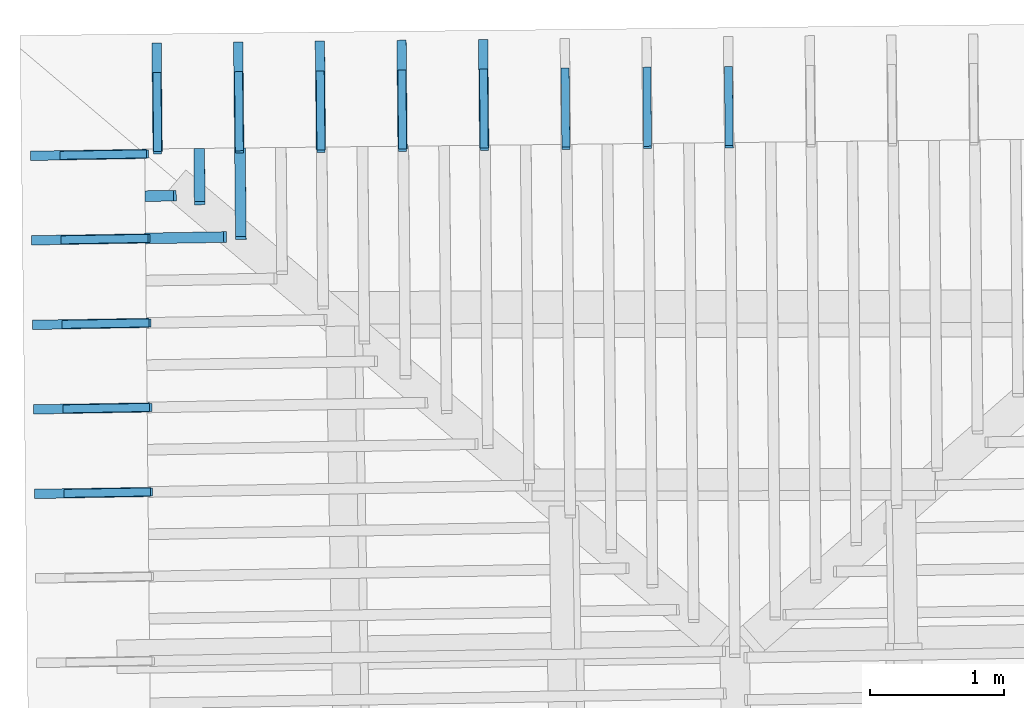
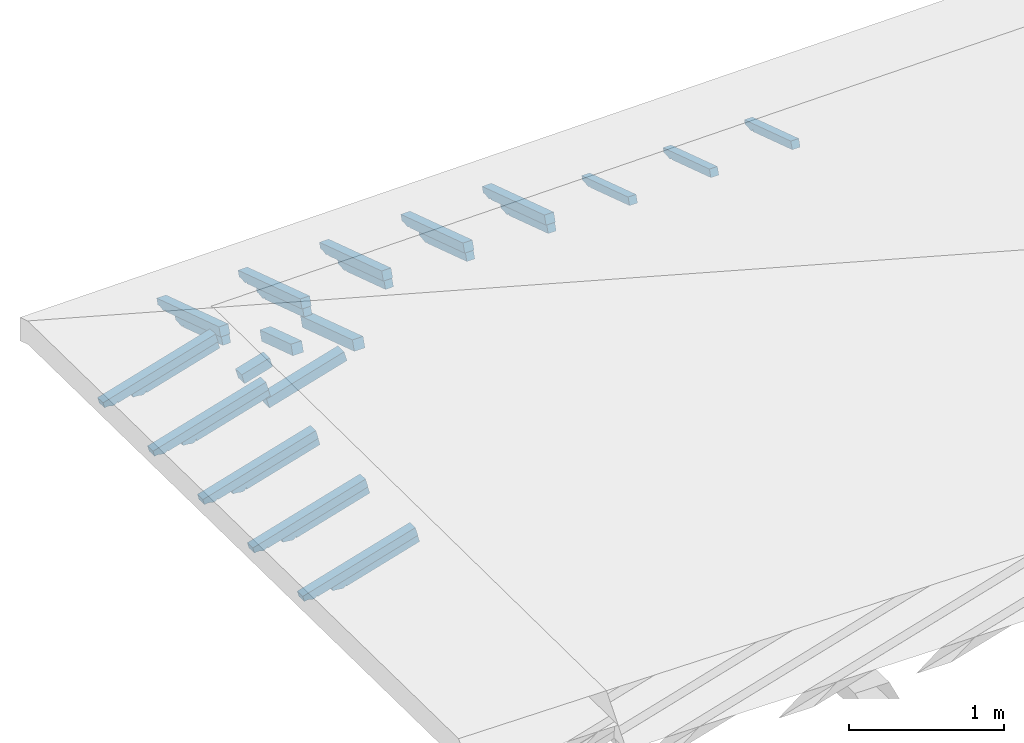
# One storey, part 15 of 19: 27 beams, 6 elements without a shape of their own.
"""IFC4 building model written with IfcOpenShell, lengths in metres."""

from ifc_helpers import new_model, entity, si_unit, converted_unit, derived_unit, direction, frame, origin, place, context, subcontext, project, spatial, line, arc, indexed_curve, outline, extrude, source, transform, mapped, material, type_object, type_shapes, element, aggregate, save


model = new_model("IFC4")

# Units and contexts
model_context = context("Model", 3, precision=1e-05, world=origin(), true_north=direction((6.123233995736766e-17, 1.0)))
body_context = subcontext(model_context, "Body", "Model", "MODEL_VIEW")
ifc_project = project(units=[si_unit("LENGTHUNIT", "METRE"), si_unit("AREAUNIT", "SQUARE_METRE"), si_unit("VOLUMEUNIT", "CUBIC_METRE"), converted_unit("PLANEANGLEUNIT", "DEGREE", entity("IfcPlaneAngleMeasure", 0.017453292519943278), si_unit("PLANEANGLEUNIT", "RADIAN"), dimensions=[0, 0, 0, 0, 0, 0, 0]), derived_unit("THERMALTRANSMITTANCEUNIT", [(si_unit("MASSUNIT", "GRAM", prefix="KILO"), 1), (si_unit("THERMODYNAMICTEMPERATUREUNIT", "KELVIN"), -1), (si_unit("TIMEUNIT", "SECOND"), -3)])], contexts=[model_context])

# Site, building, storey
site_placement = place(None, origin())
site = spatial("IfcSite", under=ifc_project, at=site_placement, CompositionType="ELEMENT")
building_placement = place(site_placement, origin())
building = spatial("IfcBuilding", under=site, at=building_placement, CompositionType="ELEMENT")
storey_placement = place(building_placement, frame((0.0, 0.0, 3.28)))
storey = spatial("IfcBuildingStorey", under=building, at=storey_placement, Name="Livello Copertura", CompositionType="ELEMENT", Elevation=3.28)

# Assembly, beams
assembly_1_placement = place(storey_placement, origin())
assembly_1 = element("IfcElementAssembly", 1, at=assembly_1_placement, inside=storey, Name="Sistema di travi strutturali:Sistema di travi strutturali", ObjectType="Sistema di travi strutturali:Sistema di travi strutturali", AssemblyPlace="NOTDEFINED", PredefinedType="BEAM_GRID")
ifc_material = material(Name="Legno - Legno da costruzione", Category="Legno")
beam_type_1 = type_object("IfcBeamType", Name="Legno:80x80", PredefinedType="JOIST", material=ifc_material)
shared_shape_1 = source(origin(), body_context, "Body", "SweptSolid", [
    extrude(outline(indexed_curve([(-0.10950000000000001, -0.04000000000000169), (0.10950000000000001, -0.04000000000000169), (0.10950000000000001, 0.04000000000000169), (-0.10950000000000001, 0.04000000000000169), (-0.10950000000000001, -0.04000000000000169)], self_intersect=False)), frame((0.0, 0.0, -0.040000000000005476), z_axis=(0.0, 0.0, 1.0), x_axis=(-1.0, 0.0, 0.0)), (0.0, 0.0, 1.0), 0.07999999999999997),
])
type_shapes(beam_type_1, [shared_shape_1])
beam_1_placement = place(assembly_1_placement, frame((-4.582253934922218, 15.732475619710598, 0.14532260116264584), z_axis=(-0.26888056974925345, -0.004594467440668278, 0.9631625667976582), x_axis=(0.9630219859926786, 0.01645553326302543, 0.26891982061526537)))
beam_1 = element("IfcBeam", 2, at=beam_1_placement, type_object=beam_type_1, material=ifc_material, Name="Legno:80x80", ObjectType="Legno:80x80", PredefinedType="JOIST", context=body_context, shape_type="MappedRepresentation", body=[
    mapped(shared_shape_1, transform((0.0, 0.0, 0.0), scale=1.0)),
])
beam_type_2 = type_object("IfcBeamType", Name="Legno:80x80", PredefinedType="JOIST", material=ifc_material)
shared_shape_2 = source(origin(), body_context, "Body", "SweptSolid", [
    extrude(outline(indexed_curve([(-0.3025, -0.04000000000000169), (0.3025, -0.04000000000000169), (0.3025, 0.04000000000000169), (-0.3025, 0.04000000000000169), (-0.3025, -0.04000000000000169)], self_intersect=False)), frame((0.0, 0.0, -0.040000000000005476), z_axis=(0.0, 0.0, 1.0), x_axis=(-1.0, 0.0, 0.0)), (0.0, 0.0, 1.0), 0.07999999999999997),
])
type_shapes(beam_type_2, [shared_shape_2])
beam_2_placement = place(assembly_1_placement, frame((-4.3932646673043765, 15.420658969904737, 0.19659422675413696), z_axis=(-0.2688805697492527, -0.004594467440668261, 0.9631625667976585), x_axis=(0.963021985992679, 0.016455533263023885, 0.26891982061526454)))
beam_2 = element("IfcBeam", 3, at=beam_2_placement, type_object=beam_type_2, material=ifc_material, Name="Legno:80x80", ObjectType="Legno:80x80", PredefinedType="JOIST", context=body_context, shape_type="MappedRepresentation", body=[
    mapped(shared_shape_2, transform((0.0, 0.0, 0.0), scale=1.0)),
])
aggregate(assembly_1, [beam_1, beam_2])

assembly_2_placement = place(storey_placement, origin())
assembly_2 = element("IfcElementAssembly", 4, at=assembly_2_placement, inside=storey, Name="Sistema di travi strutturali:Sistema di travi strutturali", ObjectType="Sistema di travi strutturali:Sistema di travi strutturali", AssemblyPlace="NOTDEFINED", PredefinedType="BEAM_GRID")
beam_type_3 = type_object("IfcBeamType", Name="Legno:80x80", PredefinedType="JOIST", material=ifc_material)
shared_shape_3 = source(origin(), body_context, "Body", "SweptSolid", [
    extrude(outline(indexed_curve([(-0.2075, -0.04000000000000169), (0.2075, -0.04000000000000169), (0.2075, 0.04000000000000169), (-0.2075, 0.04000000000000169), (-0.2075, -0.04000000000000169)], self_intersect=False)), frame((0.0, 0.0, -0.040000000000005476), z_axis=(0.0, 0.0, 1.0), x_axis=(-1.0, 0.0, 0.0)), (0.0, 0.0, 1.0), 0.07999999999999997),
])
type_shapes(beam_type_3, [shared_shape_3])
beam_3_placement = place(assembly_2_placement, frame((-4.293384356106456, 15.876184895349297, 0.16696005804398784), z_axis=(-0.007186655942142942, 0.30161875858893405, 0.9534015294951229), x_axis=(0.009276659863625233, -0.9533650144726797, 0.30167713330857865)))
beam_3 = element("IfcBeam", 5, at=beam_3_placement, type_object=beam_type_3, material=ifc_material, Name="Legno:80x80", ObjectType="Legno:80x80", PredefinedType="JOIST", context=body_context, shape_type="MappedRepresentation", body=[
    mapped(shared_shape_3, transform((0.0, 0.0, 0.0), scale=1.0)),
])
beam_type_4 = type_object("IfcBeamType", Name="Legno:80x80", PredefinedType="JOIST", material=ifc_material)
shared_shape_4 = source(origin(), body_context, "Body", "SweptSolid", [
    extrude(outline(indexed_curve([(-0.34550000000000003, -0.04000000000000169), (0.34550000000000003, -0.04000000000000169), (0.34550000000000003, 0.04000000000000169), (-0.34550000000000003, 0.04000000000000169), (-0.34550000000000003, -0.04000000000000169)], self_intersect=False)), frame((0.0, 0.0, -0.040000000000005476), z_axis=(0.0, 0.0, 1.0), x_axis=(-1.0, 0.0, 0.0)), (0.0, 0.0, 1.0), 0.07999999999999997),
])
type_shapes(beam_type_4, [shared_shape_4])
beam_4_placement = place(assembly_2_placement, frame((-3.9878263051044196, 15.748092423715986, 0.20978674921066975), z_axis=(-0.007186655942142939, 0.3016187585889339, 0.9534015294951229), x_axis=(0.009276659863626028, -0.9533650144726799, 0.3016771333085785)))
beam_4 = element("IfcBeam", 6, at=beam_4_placement, type_object=beam_type_4, material=ifc_material, Name="Legno:80x80", ObjectType="Legno:80x80", PredefinedType="JOIST", context=body_context, shape_type="MappedRepresentation", body=[
    mapped(shared_shape_4, transform((0.0, 0.0, 0.0), scale=1.0)),
])
aggregate(assembly_2, [beam_3, beam_4])

assembly_3_placement = place(storey_placement, origin())
assembly_3 = element("IfcElementAssembly", 7, at=assembly_3_placement, inside=storey, Name="Sistema di travi strutturali:Sistema di travi strutturali", ObjectType="Sistema di travi strutturali:Sistema di travi strutturali", AssemblyPlace="NOTDEFINED", PredefinedType="BEAM_GRID")
beam_type_5 = type_object("IfcBeamType", Name="70x70:70x70", PredefinedType="JOIST", material=ifc_material)
shared_shape_5 = source(origin(), body_context, "Body", "SweptSolid", [
    extrude(outline(indexed_curve([(-0.04357142857143151, -0.5561428571428565), (0.026428571428568467, -0.5561428571428565), (0.026428571428568467, 0.1728571428571433), (0.012428571428584355, 0.1728571428571399), (0.026181867029378872, 0.19656674738504454), (0.018428571428570788, 0.22285714285714342), (0.006014118110847752, 0.24585271837212633), (0.0034285714285709526, 0.27185714285714324), (-0.04357142857143151, 0.27185714285714324)], segments=[line(1, 2, 3, 4), arc(4, 5, 6), arc(6, 7, 8), line(8, 9, 1)], self_intersect=False)), frame((-0.10714285714285654, -0.03500000000000078, -0.008571428571433252), z_axis=(0.0, 1.0, 0.0), x_axis=(0.0, 0.0, -1.0)), (0.0, 0.0, 1.0), 0.06999999999999999),
])
type_shapes(beam_type_5, [shared_shape_5])
beam_5_placement = place(assembly_3_placement, frame((-4.609130134095698, 16.50076191580006, 0.10539004595002055), z_axis=(-0.007186655942142929, 0.30161875858893394, 0.9534015294951229), x_axis=(0.009276659863625622, -0.9533650144726796, 0.3016771333085786)))
beam_5 = element("IfcBeam", 8, at=beam_5_placement, type_object=beam_type_5, material=ifc_material, Name="70x70:70x70", ObjectType="70x70:70x70", PredefinedType="JOIST", context=body_context, shape_type="MappedRepresentation", body=[
    mapped(shared_shape_5, transform((0.0, 0.0, 0.0), scale=1.0)),
])
beam_6_placement = place(assembly_3_placement, frame((-4.000572039000026, 16.507464081589834, 0.10785700100738804), z_axis=(-0.007186655942142923, 0.3016187585889335, 0.953401529495123), x_axis=(0.009276659863625115, -0.95336501447268, 0.3016771333085781)))
beam_6 = element("IfcBeam", 9, at=beam_6_placement, type_object=beam_type_5, material=ifc_material, Name="70x70:70x70", ObjectType="70x70:70x70", PredefinedType="JOIST", context=body_context, shape_type="MappedRepresentation", body=[
    mapped(shared_shape_5, transform((0.0, 0.0, 0.0), scale=1.0)),
])
beam_7_placement = place(assembly_3_placement, frame((-3.392013943904355, 16.51416624737961, 0.11032395606475465), z_axis=(-0.0071866559421429246, 0.3016187585889335, 0.953401529495123), x_axis=(0.009276659863625207, -0.95336501447268, 0.3016771333085781)))
beam_7 = element("IfcBeam", 10, at=beam_7_placement, type_object=beam_type_5, material=ifc_material, Name="70x70:70x70", ObjectType="70x70:70x70", PredefinedType="JOIST", context=body_context, shape_type="MappedRepresentation", body=[
    mapped(shared_shape_5, transform((0.0, 0.0, 0.0), scale=1.0)),
])
beam_8_placement = place(assembly_3_placement, frame((-2.783455848808685, 16.52086841316939, 0.11279091112212125), z_axis=(-0.007186655942142926, 0.3016187585889337, 0.953401529495123), x_axis=(0.009276659863625325, -0.9533650144726799, 0.3016771333085783)))
beam_8 = element("IfcBeam", 11, at=beam_8_placement, type_object=beam_type_5, material=ifc_material, Name="70x70:70x70", ObjectType="70x70:70x70", PredefinedType="JOIST", context=body_context, shape_type="MappedRepresentation", body=[
    mapped(shared_shape_5, transform((0.0, 0.0, 0.0), scale=1.0)),
])
beam_9_placement = place(assembly_3_placement, frame((-2.1748977537130134, 16.527570578959164, 0.11525786617948608), z_axis=(-0.007186655942142926, 0.3016187585889336, 0.953401529495123), x_axis=(0.00927665986362572, -0.9533650144726797, 0.30167713330857826)))
beam_9 = element("IfcBeam", 12, at=beam_9_placement, type_object=beam_type_5, material=ifc_material, Name="70x70:70x70", ObjectType="70x70:70x70", PredefinedType="JOIST", context=body_context, shape_type="MappedRepresentation", body=[
    mapped(shared_shape_5, transform((0.0, 0.0, 0.0), scale=1.0)),
])
aggregate(assembly_3, [beam_5, beam_6, beam_7, beam_8, beam_9])

assembly_4_placement = place(storey_placement, origin())
assembly_4 = element("IfcElementAssembly", 13, at=assembly_4_placement, inside=storey, Name="Sistema di travi strutturali:Sistema di travi strutturali", ObjectType="Sistema di travi strutturali:Sistema di travi strutturali", AssemblyPlace="NOTDEFINED", PredefinedType="BEAM_GRID")
beam_type_6 = type_object("IfcBeamType", Name="60x60:60x60", PredefinedType="JOIST", material=ifc_material)
shared_shape_6 = source(origin(), body_context, "Body", "SweptSolid", [
    extrude(outline(indexed_curve([(-0.035857142857117906, -0.404857142857143), (0.02414285714288207, -0.404857142857143), (0.02414285714288207, 0.11414285714285698), (0.007142857142882135, 0.11414285714285698), (0.02280031419839907, 0.1317392731984247), (0.02014285714279438, 0.1551428571428581), (0.006097362558745583, 0.1832964455908379), (-0.003857142857204834, 0.21314285714285694), (-0.035857142857117906, 0.21314285714285702)], segments=[line(1, 2, 3, 4), arc(4, 5, 6), arc(6, 7, 8), line(8, 9, 1)], self_intersect=False)), frame((0.04414285714285706, -0.030000000000000786, -0.005857142857119645), z_axis=(0.0, 1.0, 0.0), x_axis=(0.0, 0.0, -1.0)), (0.0, 0.0, 1.0), 0.059999999999999984),
])
type_shapes(beam_type_6, [shared_shape_6])
beam_10_placement = place(assembly_4_placement, frame((-4.608663001459457, 16.481156696491773, 0.0434189465328334), z_axis=(-0.007186655942142926, 0.30161875858893394, 0.9534015294951229), x_axis=(0.009276659863625622, -0.9533650144726796, 0.3016771333085786)))
beam_10 = element("IfcBeam", 14, at=beam_10_placement, type_object=beam_type_6, material=ifc_material, Name="60x60:60x60", ObjectType="60x60:60x60", PredefinedType="JOIST", context=body_context, shape_type="MappedRepresentation", body=[
    mapped(shared_shape_6, transform((0.0, 0.0, 0.0), scale=1.0)),
])
beam_11_placement = place(assembly_4_placement, frame((-4.000104906363788, 16.48785886228155, 0.04588590159020178), z_axis=(-0.0071866559421429246, 0.3016187585889335, 0.9534015294951231), x_axis=(0.009276659863625115, -0.95336501447268, 0.3016771333085781)))
beam_11 = element("IfcBeam", 15, at=beam_11_placement, type_object=beam_type_6, material=ifc_material, Name="60x60:60x60", ObjectType="60x60:60x60", PredefinedType="JOIST", context=body_context, shape_type="MappedRepresentation", body=[
    mapped(shared_shape_6, transform((0.0, 0.0, 0.0), scale=1.0)),
])
beam_12_placement = place(assembly_4_placement, frame((-3.3915468112681166, 16.49456102807133, 0.0483528566475675), z_axis=(-0.007186655942142923, 0.3016187585889335, 0.9534015294951231), x_axis=(0.009276659863625207, -0.95336501447268, 0.3016771333085781)))
beam_12 = element("IfcBeam", 16, at=beam_12_placement, type_object=beam_type_6, material=ifc_material, Name="60x60:60x60", ObjectType="60x60:60x60", PredefinedType="JOIST", context=body_context, shape_type="MappedRepresentation", body=[
    mapped(shared_shape_6, transform((0.0, 0.0, 0.0), scale=1.0)),
])
beam_13_placement = place(assembly_4_placement, frame((-2.7829887161724463, 16.501263193861107, 0.050819811704934104), z_axis=(-0.0071866559421429246, 0.3016187585889337, 0.953401529495123), x_axis=(0.009276659863625325, -0.9533650144726799, 0.3016771333085783)))
beam_13 = element("IfcBeam", 17, at=beam_13_placement, type_object=beam_type_6, material=ifc_material, Name="60x60:60x60", ObjectType="60x60:60x60", PredefinedType="JOIST", context=body_context, shape_type="MappedRepresentation", body=[
    mapped(shared_shape_6, transform((0.0, 0.0, 0.0), scale=1.0)),
])
beam_14_placement = place(assembly_4_placement, frame((-2.174430621076774, 16.507965359650882, 0.053286766762301596), z_axis=(-0.0071866559421429246, 0.3016187585889336, 0.953401529495123), x_axis=(0.00927665986362572, -0.9533650144726797, 0.30167713330857826)))
beam_14 = element("IfcBeam", 18, at=beam_14_placement, type_object=beam_type_6, material=ifc_material, Name="60x60:60x60", ObjectType="60x60:60x60", PredefinedType="JOIST", context=body_context, shape_type="MappedRepresentation", body=[
    mapped(shared_shape_6, transform((0.0, 0.0, 0.0), scale=1.0)),
])
beam_15_placement = place(assembly_4_placement, frame((-1.565872525981103, 16.51466752544066, 0.05575372181966731), z_axis=(-0.007186655942142925, 0.30161875858893367, 0.953401529495123), x_axis=(0.009276659863625813, -0.9533650144726797, 0.3016771333085783)))
beam_15 = element("IfcBeam", 19, at=beam_15_placement, type_object=beam_type_6, material=ifc_material, Name="60x60:60x60", ObjectType="60x60:60x60", PredefinedType="JOIST", context=body_context, shape_type="MappedRepresentation", body=[
    mapped(shared_shape_6, transform((0.0, 0.0, 0.0), scale=1.0)),
])
beam_16_placement = place(assembly_4_placement, frame((-0.9573144308854326, 16.521369691230436, 0.05822067687703214), z_axis=(-0.007186655942142933, 0.30161875858893444, 0.9534015294951228), x_axis=(0.009276659863625778, -0.9533650144726795, 0.3016771333085791)))
beam_16 = element("IfcBeam", 20, at=beam_16_placement, type_object=beam_type_6, material=ifc_material, Name="60x60:60x60", ObjectType="60x60:60x60", PredefinedType="JOIST", context=body_context, shape_type="MappedRepresentation", body=[
    mapped(shared_shape_6, transform((0.0, 0.0, 0.0), scale=1.0)),
])
beam_17_placement = place(assembly_4_placement, frame((-0.3487563357897622, 16.52807185702022, 0.06068763193439608), z_axis=(-0.007186655942142919, 0.3016187585889333, 0.9534015294951231), x_axis=(0.009276659863625625, -0.95336501447268, 0.30167713330857787)))
beam_17 = element("IfcBeam", 21, at=beam_17_placement, type_object=beam_type_6, material=ifc_material, Name="60x60:60x60", ObjectType="60x60:60x60", PredefinedType="JOIST", context=body_context, shape_type="MappedRepresentation", body=[
    mapped(shared_shape_6, transform((0.0, 0.0, 0.0), scale=1.0)),
])
aggregate(assembly_4, [beam_10, beam_11, beam_12, beam_13, beam_14, beam_15, beam_16, beam_17])

assembly_5_placement = place(storey_placement, origin())
assembly_5 = element("IfcElementAssembly", 22, at=assembly_5_placement, inside=storey, Name="Sistema di travi strutturali:Sistema di travi strutturali", ObjectType="Sistema di travi strutturali:Sistema di travi strutturali", AssemblyPlace="NOTDEFINED", PredefinedType="BEAM_GRID")
beam_type_7 = type_object("IfcBeamType", Name="70x70:70x70", PredefinedType="JOIST", material=ifc_material)
shared_shape_7 = source(origin(), body_context, "Body", "SweptSolid", [
    extrude(outline(indexed_curve([(-0.043571428571431495, -0.5925714285714281), (0.026428571428568505, -0.5925714285714281), (0.026428571428568505, 0.18742857142857194), (0.012428571428584407, 0.18742857142856856), (0.026181867029378924, 0.2111381759564732), (0.018428571428570704, 0.23742857142857207), (0.006014118110847667, 0.260424146943555), (0.0034285714285708724, 0.2864285714285719), (-0.043571428571431495, 0.2864285714285719)], segments=[line(1, 2, 3, 4), arc(4, 5, 6), arc(6, 7, 8), line(8, 9, 1)], self_intersect=False)), frame((-0.11807142857142808, -0.03500000000000078, -0.00857142857143322), z_axis=(0.0, 1.0, 0.0), x_axis=(0.0, 0.0, -1.0)), (0.0, 0.0, 1.0), 0.06999999999999999),
])
type_shapes(beam_type_7, [shared_shape_7])
beam_18_placement = place(assembly_5_placement, frame((-5.1243446077535815, 13.517890821120742, 0.12049828356343428), z_axis=(-0.2688805697492533, -0.004594467440668784, 0.9631625667976583), x_axis=(0.9630219859926786, 0.016455533263033163, 0.26891982061526526)))
beam_18 = element("IfcBeam", 23, at=beam_18_placement, type_object=beam_type_7, material=ifc_material, Name="70x70:70x70", ObjectType="70x70:70x70", PredefinedType="JOIST", context=body_context, shape_type="MappedRepresentation", body=[
    mapped(shared_shape_7, transform((0.0, 0.0, 0.0), scale=1.0)),
])
beam_type_8 = type_object("IfcBeamType", Name="70x70:70x70", PredefinedType="JOIST", material=ifc_material)
shared_shape_8 = source(origin(), body_context, "Body", "SweptSolid", [
    extrude(outline(indexed_curve([(-0.04357142857143151, -0.5932857142857139), (0.026428571428568484, -0.5932857142857139), (0.026428571428568484, 0.18771428571428622), (0.012428571428584384, 0.18771428571428284), (0.026181867029378903, 0.21142389024218747), (0.01842857142857075, 0.23771428571428635), (0.006014118110847714, 0.26070986122926926), (0.0034285714285709197, 0.2867142857142862), (-0.04357142857143151, 0.2867142857142862)], segments=[line(1, 2, 3, 4), arc(4, 5, 6), arc(6, 7, 8), line(8, 9, 1)], self_intersect=False)), frame((-0.11828571428571381, -0.03500000000000078, -0.008571428571433238), z_axis=(0.0, 1.0, 0.0), x_axis=(0.0, 0.0, -1.0)), (0.0, 0.0, 1.0), 0.06999999999999999),
])
type_shapes(beam_type_8, [shared_shape_8])
beam_19_placement = place(assembly_5_placement, frame((-5.131125982898225, 14.147866911763051, 0.12161027094874166), z_axis=(-0.26888056974925323, -0.004594467440668785, 0.9631625667976583), x_axis=(0.9630219859926786, 0.016455533263032632, 0.2689198206152652)))
beam_19 = element("IfcBeam", 24, at=beam_19_placement, type_object=beam_type_8, material=ifc_material, Name="70x70:70x70", ObjectType="70x70:70x70", PredefinedType="JOIST", context=body_context, shape_type="MappedRepresentation", body=[
    mapped(shared_shape_8, transform((0.0, 0.0, 0.0), scale=1.0)),
])
beam_type_9 = type_object("IfcBeamType", Name="70x70:70x70", PredefinedType="JOIST", material=ifc_material)
shared_shape_9 = source(origin(), body_context, "Body", "SweptSolid", [
    extrude(outline(indexed_curve([(-0.043571428571431536, -0.5939999999999996), (0.026428571428568453, -0.5939999999999996), (0.026428571428568453, 0.1880000000000005), (0.012428571428584355, 0.1879999999999971), (0.026181867029378872, 0.21170960452790177), (0.018428571428570822, 0.23800000000000066), (0.006014118110847787, 0.26099557551498354), (0.003428571428570993, 0.2870000000000005), (-0.043571428571431536, 0.2870000000000005)], segments=[line(1, 2, 3, 4), arc(4, 5, 6), arc(6, 7, 8), line(8, 9, 1)], self_intersect=False)), frame((-0.11849999999999952, -0.03500000000000078, -0.008571428571433268), z_axis=(0.0, 1.0, 0.0), x_axis=(0.0, 0.0, -1.0)), (0.0, 0.0, 1.0), 0.06999999999999999),
])
type_shapes(beam_type_9, [shared_shape_9])
beam_20_placement = place(assembly_5_placement, frame((-5.1379073580428685, 14.777843002405358, 0.12272225833405237), z_axis=(-0.26888056974925306, -0.004594467440668779, 0.9631625667976584), x_axis=(0.9630219859926787, 0.016455533263032122, 0.268919820615265)))
beam_20 = element("IfcBeam", 25, at=beam_20_placement, type_object=beam_type_9, material=ifc_material, Name="70x70:70x70", ObjectType="70x70:70x70", PredefinedType="JOIST", context=body_context, shape_type="MappedRepresentation", body=[
    mapped(shared_shape_9, transform((0.0, 0.0, 0.0), scale=1.0)),
])
beam_type_10 = type_object("IfcBeamType", Name="70x70:70x70", PredefinedType="JOIST", material=ifc_material)
shared_shape_10 = source(origin(), body_context, "Body", "SweptSolid", [
    extrude(outline(indexed_curve([(-0.04357142857143148, -0.5947142857142853), (0.026428571428568495, -0.5947142857142853), (0.026428571428568495, 0.18828571428571472), (0.012428571428584384, 0.18828571428571134), (0.026181867029378903, 0.211995318813616), (0.01842857142857071, 0.23828571428571502), (0.006014118110847678, 0.2612812898006979), (0.003428571428570883, 0.2872857142857148), (-0.04357142857143148, 0.2872857142857148)], segments=[line(1, 2, 3, 4), arc(4, 5, 6), arc(6, 7, 8), line(8, 9, 1)], self_intersect=False)), frame((-0.1187142857142852, -0.03500000000000078, -0.008571428571433224), z_axis=(0.0, 1.0, 0.0), x_axis=(0.0, 0.0, -1.0)), (0.0, 0.0, 1.0), 0.06999999999999999),
])
type_shapes(beam_type_10, [shared_shape_10])
beam_21_placement = place(assembly_5_placement, frame((-5.144688733187512, 15.407819093047673, 0.12383424571936041), z_axis=(-0.26888056974925356, -0.004594467440668789, 0.9631625667976583), x_axis=(0.9630219859926786, 0.01645553326303163, 0.2689198206152655)))
beam_21 = element("IfcBeam", 26, at=beam_21_placement, type_object=beam_type_10, material=ifc_material, Name="70x70:70x70", ObjectType="70x70:70x70", PredefinedType="JOIST", context=body_context, shape_type="MappedRepresentation", body=[
    mapped(shared_shape_10, transform((0.0, 0.0, 0.0), scale=1.0)),
])
beam_type_11 = type_object("IfcBeamType", Name="70x70:70x70", PredefinedType="JOIST", material=ifc_material)
shared_shape_11 = source(origin(), body_context, "Body", "SweptSolid", [
    extrude(outline(indexed_curve([(-0.04357142857143152, -0.5918571428571423), (0.026428571428568467, -0.5918571428571423), (0.026428571428568467, 0.1871428571428576), (0.012428571428584367, 0.18714285714285422), (0.026181867029378882, 0.21085246167075886), (0.018428571428570798, 0.23714285714285774), (0.006014118110847763, 0.26013843265784065), (0.0034285714285709687, 0.2861428571428576), (-0.04357142857143152, 0.2861428571428576)], segments=[line(1, 2, 3, 4), arc(4, 5, 6), arc(6, 7, 8), line(8, 9, 1)], self_intersect=False)), frame((-0.11785714285714236, -0.03500000000000078, -0.008571428571433257), z_axis=(0.0, 1.0, 0.0), x_axis=(0.0, 0.0, -1.0)), (0.0, 0.0, 1.0), 0.06999999999999999),
])
type_shapes(beam_type_11, [shared_shape_11])
beam_22_placement = place(assembly_5_placement, frame((-5.154192466640167, 16.037748665689, 0.12418602604970252), z_axis=(-0.2688805697492532, -0.004594467440668783, 0.9631625667976583), x_axis=(0.9630219859926786, 0.016455533263032052, 0.2689198206152651)))
beam_22 = element("IfcBeam", 27, at=beam_22_placement, type_object=beam_type_11, material=ifc_material, Name="70x70:70x70", ObjectType="70x70:70x70", PredefinedType="JOIST", context=body_context, shape_type="MappedRepresentation", body=[
    mapped(shared_shape_11, transform((0.0, 0.0, 0.0), scale=1.0)),
])
aggregate(assembly_5, [beam_18, beam_19, beam_20, beam_21, beam_22])

assembly_6_placement = place(storey_placement, origin())
assembly_6 = element("IfcElementAssembly", 28, at=assembly_6_placement, inside=storey, Name="Sistema di travi strutturali:Sistema di travi strutturali", ObjectType="Sistema di travi strutturali:Sistema di travi strutturali", AssemblyPlace="NOTDEFINED", PredefinedType="BEAM_GRID")
beam_type_12 = type_object("IfcBeamType", Name="60x60:60x60", PredefinedType="JOIST", material=ifc_material)
shared_shape_12 = source(origin(), body_context, "Body", "SweptSolid", [
    extrude(outline(indexed_curve([(-0.035857142857117275, -0.4412857142857144), (0.024142857142882706, -0.4412857142857144), (0.024142857142882706, 0.12871428571428561), (0.007142857142882865, 0.12871428571428567), (0.022800314198399802, 0.1463107017698534), (0.020142857142792746, 0.16971428571428657), (0.00609736255874395, 0.19786787416226634), (-0.003857142857206467, 0.2277142857142854), (-0.035857142857117275, 0.22771428571428565)], segments=[line(1, 2, 3, 4), arc(4, 5, 6), arc(6, 7, 8), line(8, 9, 1)], self_intersect=False)), frame((0.03321428571428553, -0.030000000000000786, -0.00585714285711901), z_axis=(0.0, 1.0, 0.0), x_axis=(0.0, 0.0, -1.0)), (0.0, 0.0, 1.0), 0.059999999999999984),
])
type_shapes(beam_type_12, [shared_shape_12])
beam_23_placement = place(assembly_6_placement, frame((-5.106867370719879, 13.518189461504386, 0.05789271672158569), z_axis=(-0.2688805697492533, -0.004594467440668784, 0.9631625667976583), x_axis=(0.9630219859926786, 0.016455533263033163, 0.26891982061526526)))
beam_23 = element("IfcBeam", 29, at=beam_23_placement, type_object=beam_type_12, material=ifc_material, Name="60x60:60x60", ObjectType="60x60:60x60", PredefinedType="JOIST", context=body_context, shape_type="MappedRepresentation", body=[
    mapped(shared_shape_12, transform((0.0, 0.0, 0.0), scale=1.0)),
])
beam_type_13 = type_object("IfcBeamType", Name="60x60:60x60", PredefinedType="JOIST", material=ifc_material)
shared_shape_13 = source(origin(), body_context, "Body", "SweptSolid", [
    extrude(outline(indexed_curve([(-0.0358571428571177, -0.4420000000000002), (0.024142857142882283, -0.4420000000000002), (0.024142857142882283, 0.12899999999999986), (0.007142857142882347, 0.12899999999999986), (0.02280031419839928, 0.14659641605556759), (0.020142857142793846, 0.170000000000001), (0.0060973625587450505, 0.19815358844798078), (-0.003857142857205366, 0.22799999999999981), (-0.0358571428571177, 0.22799999999999987)], segments=[line(1, 2, 3, 4), arc(4, 5, 6), arc(6, 7, 8), line(8, 9, 1)], self_intersect=False)), frame((0.03299999999999989, -0.030000000000000786, -0.005857142857119433), z_axis=(0.0, 1.0, 0.0), x_axis=(0.0, 0.0, -1.0)), (0.0, 0.0, 1.0), 0.059999999999999984),
])
type_shapes(beam_type_13, [shared_shape_13])
beam_24_placement = place(assembly_6_placement, frame((-5.1136487458645234, 14.148165552146695, 0.05900470410689396), z_axis=(-0.26888056974925323, -0.004594467440668785, 0.9631625667976583), x_axis=(0.9630219859926786, 0.016455533263032632, 0.2689198206152652)))
beam_24 = element("IfcBeam", 30, at=beam_24_placement, type_object=beam_type_13, material=ifc_material, Name="60x60:60x60", ObjectType="60x60:60x60", PredefinedType="JOIST", context=body_context, shape_type="MappedRepresentation", body=[
    mapped(shared_shape_13, transform((0.0, 0.0, 0.0), scale=1.0)),
])
beam_type_14 = type_object("IfcBeamType", Name="60x60:60x60", PredefinedType="JOIST", material=ifc_material)
shared_shape_14 = source(origin(), body_context, "Body", "SweptSolid", [
    extrude(outline(indexed_curve([(-0.035857142857117705, -0.442714285714286), (0.024142857142882276, -0.442714285714286), (0.024142857142882276, 0.12928571428571417), (0.007142857142882338, 0.12928571428571417), (0.02280031419839927, 0.1468821303412819), (0.020142857142793874, 0.17028571428571532), (0.006097362558745075, 0.1984393027336951), (-0.003857142857205342, 0.22828571428571412), (-0.035857142857117705, 0.2282857142857142)], segments=[line(1, 2, 3, 4), arc(4, 5, 6), arc(6, 7, 8), line(8, 9, 1)], self_intersect=False)), frame((0.03278571428571417, -0.030000000000000786, -0.005857142857119442), z_axis=(0.0, 1.0, 0.0), x_axis=(0.0, 0.0, -1.0)), (0.0, 0.0, 1.0), 0.059999999999999984),
])
type_shapes(beam_type_14, [shared_shape_14])
beam_25_placement = place(assembly_6_placement, frame((-5.120430121009167, 14.778141642789002, 0.06011669149220422), z_axis=(-0.26888056974925306, -0.004594467440668779, 0.9631625667976584), x_axis=(0.9630219859926787, 0.016455533263032122, 0.268919820615265)))
beam_25 = element("IfcBeam", 31, at=beam_25_placement, type_object=beam_type_14, material=ifc_material, Name="60x60:60x60", ObjectType="60x60:60x60", PredefinedType="JOIST", context=body_context, shape_type="MappedRepresentation", body=[
    mapped(shared_shape_14, transform((0.0, 0.0, 0.0), scale=1.0)),
])
beam_type_15 = type_object("IfcBeamType", Name="60x60:60x60", PredefinedType="JOIST", material=ifc_material)
shared_shape_15 = source(origin(), body_context, "Body", "SweptSolid", [
    extrude(outline(indexed_curve([(-0.03585714285711792, -0.44342857142857167), (0.02414285714288206, -0.44342857142857167), (0.02414285714288206, 0.12957142857142845), (0.007142857142882124, 0.12957142857142845), (0.022800314198399056, 0.1471678446269962), (0.0201428571427944, 0.1705714285714296), (0.006097362558745606, 0.19872501701940937), (-0.003857142857204811, 0.22857142857142843), (-0.03585714285711792, 0.22857142857142848)], segments=[line(1, 2, 3, 4), arc(4, 5, 6), arc(6, 7, 8), line(8, 9, 1)], self_intersect=False)), frame((0.032571428571428446, -0.030000000000000786, -0.005857142857119656), z_axis=(0.0, 1.0, 0.0), x_axis=(0.0, 0.0, -1.0)), (0.0, 0.0, 1.0), 0.059999999999999984),
])
type_shapes(beam_type_15, [shared_shape_15])
beam_26_placement = place(assembly_6_placement, frame((-5.12721149615381, 15.40811773343132, 0.061228678877512266), z_axis=(-0.26888056974925356, -0.004594467440668789, 0.9631625667976583), x_axis=(0.9630219859926786, 0.01645553326303163, 0.2689198206152655)))
beam_26 = element("IfcBeam", 32, at=beam_26_placement, type_object=beam_type_15, material=ifc_material, Name="60x60:60x60", ObjectType="60x60:60x60", PredefinedType="JOIST", context=body_context, shape_type="MappedRepresentation", body=[
    mapped(shared_shape_15, transform((0.0, 0.0, 0.0), scale=1.0)),
])
beam_type_16 = type_object("IfcBeamType", Name="60x60:60x60", PredefinedType="JOIST", material=ifc_material)
shared_shape_16 = source(origin(), body_context, "Body", "SweptSolid", [
    extrude(outline(indexed_curve([(-0.035857142857117656, -0.4405714285714287), (0.02414285714288232, -0.4405714285714287), (0.02414285714288232, 0.12842857142857128), (0.0071428571428823855, 0.12842857142857128), (0.02280031419839932, 0.146024987484139), (0.02014285714279375, 0.1694285714285724), (0.006097362558744953, 0.1975821598765522), (-0.0038571428572054633, 0.22742857142857123), (-0.035857142857117656, 0.2274285714285713)], segments=[line(1, 2, 3, 4), arc(4, 5, 6), arc(6, 7, 8), line(8, 9, 1)], self_intersect=False)), frame((0.03342857142857134, -0.030000000000000786, -0.005857142857119395), z_axis=(0.0, 1.0, 0.0), x_axis=(0.0, 0.0, -1.0)), (0.0, 0.0, 1.0), 0.059999999999999984),
])
type_shapes(beam_type_16, [shared_shape_16])
beam_27_placement = place(assembly_6_placement, frame((-5.136715229606464, 16.038047306072645, 0.061580459207854155), z_axis=(-0.2688805697492532, -0.004594467440668783, 0.9631625667976583), x_axis=(0.9630219859926786, 0.016455533263032052, 0.2689198206152651)))
beam_27 = element("IfcBeam", 33, at=beam_27_placement, type_object=beam_type_16, material=ifc_material, Name="60x60:60x60", ObjectType="60x60:60x60", PredefinedType="JOIST", context=body_context, shape_type="MappedRepresentation", body=[
    mapped(shared_shape_16, transform((0.0, 0.0, 0.0), scale=1.0)),
])
aggregate(assembly_6, [beam_23, beam_24, beam_25, beam_26, beam_27])

save(model, "model.ifc")
